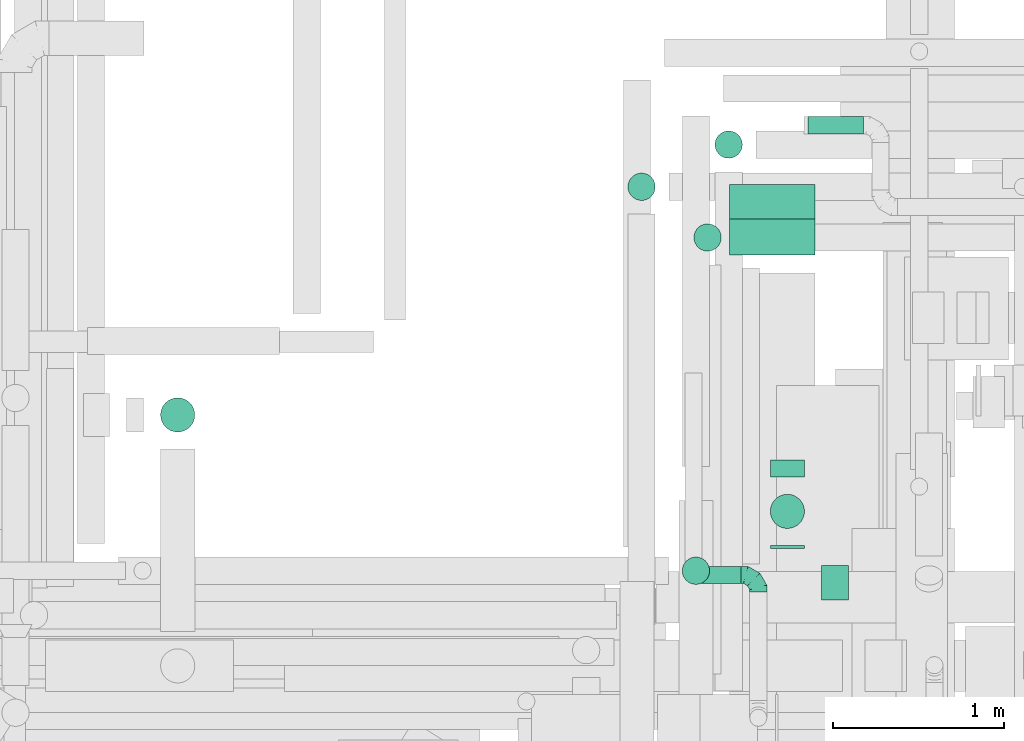
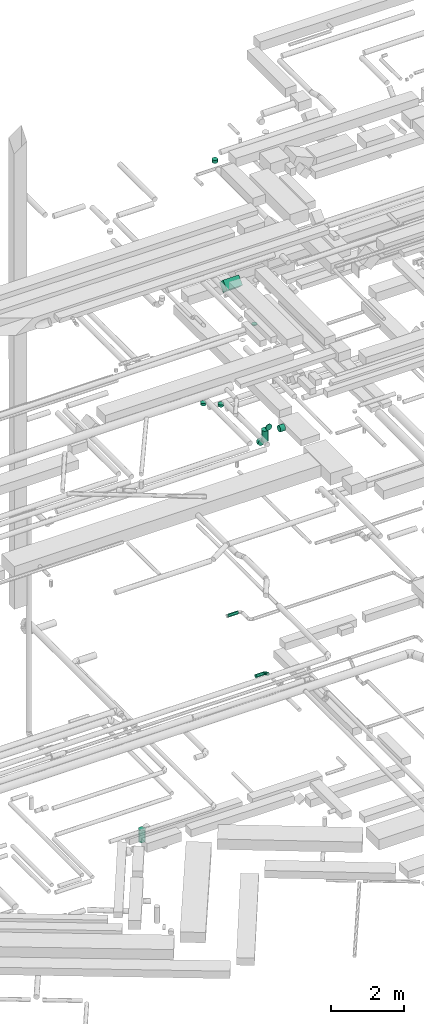
# One storey, part 108 of 337: 12 flow segments, 1 flow fitting.
"""IFC2X3 building model written with IfcOpenShell, lengths in millimetres."""

from ifc_helpers import new_model, entity, si_unit, converted_unit, derived_unit, direction, frame, frame_2d, origin, origin_2d_with_axis, place, context, subcontext, project, spatial, rectangle, circle, extrude, faceted_brep, source, transform, mapped, material, type_object, type_shapes, element, save


model = new_model("IFC2X3")

# Units and contexts
model_context = context("Model", 3, precision=0.01, world=origin(), true_north=direction((6.12303176911189e-17, 1.0)))
body_context = subcontext(model_context, "Body", "Model", "MODEL_VIEW")
ifc_project = project(units=[si_unit("LENGTHUNIT", "METRE", prefix="MILLI"), si_unit("AREAUNIT", "SQUARE_METRE"), si_unit("VOLUMEUNIT", "CUBIC_METRE"), converted_unit("PLANEANGLEUNIT", "DEGREE", entity("IfcRatioMeasure", 0.0174532925199433), si_unit("PLANEANGLEUNIT", "RADIAN"), dimensions=[0, 0, 0, 0, 0, 0, 0]), si_unit("MASSUNIT", "GRAM", prefix="KILO"), derived_unit("MASSDENSITYUNIT", [(si_unit("MASSUNIT", "GRAM", prefix="KILO"), 1), (si_unit("LENGTHUNIT", "METRE"), -3)]), derived_unit("MOMENTOFINERTIAUNIT", [(si_unit("LENGTHUNIT", "METRE"), 4)]), si_unit("TIMEUNIT", "SECOND"), si_unit("FREQUENCYUNIT", "HERTZ"), si_unit("THERMODYNAMICTEMPERATUREUNIT", "DEGREE_CELSIUS"), derived_unit("THERMALTRANSMITTANCEUNIT", [(si_unit("MASSUNIT", "GRAM", prefix="KILO"), 1), (si_unit("THERMODYNAMICTEMPERATUREUNIT", "KELVIN"), -1), (si_unit("TIMEUNIT", "SECOND"), -3)]), derived_unit("VOLUMETRICFLOWRATEUNIT", [(si_unit("LENGTHUNIT", "METRE"), 3), (si_unit("TIMEUNIT", "SECOND"), -1)]), derived_unit("MASSFLOWRATEUNIT", [(si_unit("MASSUNIT", "GRAM", prefix="KILO"), 1), (si_unit("TIMEUNIT", "SECOND"), -1)]), derived_unit("ROTATIONALFREQUENCYUNIT", [(si_unit("TIMEUNIT", "SECOND"), -1)]), si_unit("ELECTRICCURRENTUNIT", "AMPERE"), si_unit("ELECTRICVOLTAGEUNIT", "VOLT"), si_unit("POWERUNIT", "WATT"), si_unit("FORCEUNIT", "NEWTON", prefix="KILO"), si_unit("ILLUMINANCEUNIT", "LUX"), si_unit("LUMINOUSFLUXUNIT", "LUMEN"), si_unit("LUMINOUSINTENSITYUNIT", "CANDELA"), derived_unit("USERDEFINED", [(si_unit("MASSUNIT", "GRAM", prefix="KILO"), -1), (si_unit("LENGTHUNIT", "METRE"), -2), (si_unit("TIMEUNIT", "SECOND"), 3), (si_unit("LUMINOUSFLUXUNIT", "LUMEN"), 1)]), derived_unit("LINEARVELOCITYUNIT", [(si_unit("LENGTHUNIT", "METRE"), 1), (si_unit("TIMEUNIT", "SECOND"), -1)]), si_unit("PRESSUREUNIT", "PASCAL"), derived_unit("USERDEFINED", [(si_unit("LENGTHUNIT", "METRE"), -2), (si_unit("MASSUNIT", "GRAM", prefix="KILO"), 1), (si_unit("TIMEUNIT", "SECOND"), -2)]), derived_unit("LINEARFORCEUNIT", [(si_unit("MASSUNIT", "GRAM", prefix="KILO"), 1), (si_unit("LENGTHUNIT", "METRE"), 1), (si_unit("TIMEUNIT", "SECOND"), -2), (si_unit("LENGTHUNIT", "METRE"), -1)]), derived_unit("PLANARFORCEUNIT", [(si_unit("MASSUNIT", "GRAM", prefix="KILO"), 1), (si_unit("LENGTHUNIT", "METRE"), 1), (si_unit("TIMEUNIT", "SECOND"), -2), (si_unit("LENGTHUNIT", "METRE"), -2)])], contexts=[model_context])

# Site, building, storey
site_placement = place(None, origin())
site = spatial("IfcSite", under=ifc_project, at=site_placement, CompositionType="ELEMENT")
building_placement = place(site_placement, origin())
building = spatial("IfcBuilding", under=site, at=building_placement, CompositionType="ELEMENT")
storey_placement = place(building_placement, origin())
storey = spatial("IfcBuildingStorey", under=building, at=storey_placement, CompositionType="ELEMENT", Elevation=0.0)

# Flow segments
duct_segment_type_1 = type_object("IfcDuctSegmentType", PredefinedType="NOTDEFINED")
flow_segment_1_placement = place(storey_placement, frame((17425.0, 15035.4, 14906.8)))
element("IfcFlowSegment", 1, at=flow_segment_1_placement, inside=storey, type_object=duct_segment_type_1, context=body_context, shape_type="SweptSolid", body=[
    extrude(rectangle(XDim=300.0, YDim=281.801934957959, at=frame_2d((0.0, 0.0), x_axis=(0.0, 1.0))), frame((0.0, 205.7, 205.7), z_axis=(1.0, 0.0, 0.0), x_axis=(0.0, -0.707106781186551, 0.707106781186544)), (0.0, 0.0, 1.0), 499.999999999999),
])
duct_segment_type_2 = type_object("IfcDuctSegmentType", PredefinedType="NOTDEFINED")
flow_segment_2_placement = place(storey_placement, frame((14097.4, 13999.38, -1603.0)))
element("IfcFlowSegment", 2, at=flow_segment_2_placement, inside=storey, type_object=duct_segment_type_2, context=body_context, shape_type="SweptSolid", body=[
    extrude(circle(Radius=100.0, at=origin_2d_with_axis()), frame((101.6, 101.6, 0.0), z_axis=(0.0, 0.0, 1.0), x_axis=(-1.0, 0.0, 0.0)), (0.0, 0.0, 1.0), 403.000000000009),
])
flow_segment_3_placement = place(storey_placement, frame((17963.84, 13017.67, 11348.4)))
element("IfcFlowSegment", 3, at=flow_segment_3_placement, inside=storey, type_object=duct_segment_type_2, context=body_context, shape_type="SweptSolid", body=[
    extrude(circle(Radius=100.0, at=origin_2d_with_axis()), frame((0.0, 101.6, 101.6), z_axis=(1.0, 0.0, 0.0), x_axis=(0.0, 1.0, 0.0)), (0.0, 0.0, 1.0), 157.976677720794),
])
flow_segment_4_placement = place(storey_placement, frame((17248.66, 13113.76, 3348.4)))
element("IfcFlowSegment", 4, at=flow_segment_4_placement, inside=storey, type_object=duct_segment_type_2, context=body_context, shape_type="SweptSolid", body=[
    extrude(circle(Radius=50.0, at=origin_2d_with_axis()), frame((0.0, 51.6, 51.6), z_axis=(1.0, 0.0, 0.0), x_axis=(0.0, 1.0, 0.0)), (0.0, 0.0, 1.0), 245.00000000002),
])
flow_segment_5_placement = place(storey_placement, frame((17884.69, 15743.28, 3548.4)))
element("IfcFlowSegment", 5, at=flow_segment_5_placement, inside=storey, type_object=duct_segment_type_2, context=body_context, shape_type="SweptSolid", body=[
    extrude(circle(Radius=50.0, at=origin_2d_with_axis()), frame((0.0, 51.6, 51.6), z_axis=(1.0, 0.0, 0.0), x_axis=(0.0, 1.0, 0.0)), (0.0, 0.0, 1.0), 323.749999999978),
])
flow_segment_6_placement = place(storey_placement, frame((17662.24, 13319.26, 11348.4)))
element("IfcFlowSegment", 6, at=flow_segment_6_placement, inside=storey, type_object=duct_segment_type_2, context=body_context, shape_type="SweptSolid", body=[
    extrude(circle(Radius=100.0, at=origin_2d_with_axis()), frame((101.6, 0.0, 101.6), z_axis=(0.0, 1.0, 0.0), x_axis=(1.0, 0.0, 0.0)), (0.0, 0.0, 1.0), 17.8476961971333),
])
flow_segment_7_placement = place(storey_placement, frame((17662.24, 13737.11, 10578.71)))
element("IfcFlowSegment", 7, at=flow_segment_7_placement, inside=storey, type_object=duct_segment_type_2, context=body_context, shape_type="SweptSolid", body=[
    extrude(circle(Radius=100.0, at=origin_2d_with_axis()), frame((101.6, 0.0, 101.6), z_axis=(0.0, 1.0, 0.0), x_axis=(-1.0, 0.0, 0.0)), (0.0, 0.0, 1.0), 100.000000000014),
])
flow_segment_8_placement = place(storey_placement, frame((17662.24, 13435.51, 10880.3)))
element("IfcFlowSegment", 8, at=flow_segment_8_placement, inside=storey, type_object=duct_segment_type_2, context=body_context, shape_type="SweptSolid", body=[
    extrude(circle(Radius=100.0, at=origin_2d_with_axis()), frame((101.6, 101.6, 0.0), z_axis=(0.0, 0.0, 1.0), x_axis=(-1.0, 0.0, 0.0)), (0.0, 0.0, 1.0), 369.695765711637),
])
flow_segment_9_placement = place(storey_placement, frame((17215.73, 15056.69, 11230.0)))
element("IfcFlowSegment", 9, at=flow_segment_9_placement, inside=storey, type_object=duct_segment_type_2, context=body_context, shape_type="SweptSolid", body=[
    extrude(circle(Radius=80.0, at=origin_2d_with_axis()), frame((81.6, 81.6, 0.0), z_axis=(0.0, 0.0, 1.0), x_axis=(-1.0, 0.0, 0.0)), (0.0, 0.0, 1.0), 80.00000000001),
])
flow_segment_10_placement = place(storey_placement, frame((16829.74, 15353.25, 11230.0)))
element("IfcFlowSegment", 10, at=flow_segment_10_placement, inside=storey, type_object=duct_segment_type_2, context=body_context, shape_type="SweptSolid", body=[
    extrude(circle(Radius=80.0, at=origin_2d_with_axis()), frame((81.6, 81.6, 0.0), z_axis=(0.0, 0.0, 1.0), x_axis=(-1.0, 0.0, 0.0)), (0.0, 0.0, 1.0), 80.0027229055657),
])
flow_segment_11_placement = place(storey_placement, frame((17338.9, 15599.81, 19010.0)))
element("IfcFlowSegment", 11, at=flow_segment_11_placement, inside=storey, type_object=duct_segment_type_2, context=body_context, shape_type="SweptSolid", body=[
    extrude(circle(Radius=80.0, at=origin_2d_with_axis()), frame((81.6, 81.6, 0.0)), (0.0, 0.0, 1.0), 100.000000000012),
])
flow_segment_12_placement = place(storey_placement, frame((17147.62, 13108.4, 15160.0)))
element("IfcFlowSegment", 12, at=flow_segment_12_placement, inside=storey, type_object=duct_segment_type_2, context=body_context, shape_type="SweptSolid", body=[
    extrude(circle(Radius=80.0, at=origin_2d_with_axis()), frame((81.6, 81.6, 0.0), z_axis=(0.0, 0.0, 1.0), x_axis=(0.0, -1.0, 0.0)), (0.0, 0.0, 1.0), 19.9999952434063),
])

# Flow fitting
ifc_material = material()
duct_fitting_type = type_object("IfcDuctFittingType", PredefinedType="NOTDEFINED", material=ifc_material)
shared_shape = source(origin(), body_context, "Body", "Brep", [
    faceted_brep([(-100.0, 0.0, -50.0), (-100.0, -12.94, -48.3), (-100.0, -25.0, -43.3), (-100.0, -35.36, -35.36), (-100.0, -43.3, -25.0), (-100.0, -48.3, -12.94), (-100.0, -50.0, 0.0), (-100.0, -48.3, 12.94), (-100.0, -43.3, 25.0), (-100.0, -35.36, 35.36), (-100.0, -25.0, 43.3), (-100.0, -12.94, 48.3), (-100.0, 0.0, 50.0), (-100.0, 12.94, 48.3), (-100.0, 25.0, 43.3), (-100.0, 35.36, 35.36), (-100.0, 43.3, 25.0), (-100.0, 48.3, 12.94), (-100.0, 50.0, 0.0), (-100.0, 48.3, -12.94), (-100.0, 43.3, -25.0), (-100.0, 35.36, -35.36), (-100.0, 25.0, -43.3), (-100.0, 12.94, -48.3), (-76.67, 12.94, 48.3), (-79.9, 25.0, 43.3), (-73.21, 0.0, 50.0), (-82.68, 35.36, 35.36), (-86.15, 48.3, 12.94), (-86.6, 50.0, 0.0), (-84.81, 43.3, 25.0), (-84.81, 43.3, -25.0), (-82.68, 35.36, -35.36), (-86.15, 48.3, -12.94), (-76.67, 12.94, -48.3), (-73.21, 0.0, -50.0), (-79.9, 25.0, -43.3), (-69.74, -12.94, -48.3), (-66.51, -25.0, -43.3), (-63.73, -35.36, -35.36), (-61.6, -43.3, -25.0), (-60.26, -48.3, -12.94), (-59.81, -50.0, 0.0), (-60.26, -48.3, 12.94), (-61.6, -43.3, 25.0), (-63.73, -35.36, 35.36), (-66.51, -25.0, 43.3), (-69.74, -12.94, 48.3), (-36.27, 36.27, 48.3), (-45.1, 45.1, 43.3), (-26.79, 26.79, 50.0), (-52.68, 52.68, 35.36), (-58.49, 58.49, 25.0), (-62.15, 62.15, 12.94), (-63.4, 63.4, 0.0), (-62.15, 62.15, -12.94), (-58.49, 58.49, -25.0), (-52.68, 52.68, -35.36), (-36.27, 36.27, -48.3), (-26.79, 26.79, -50.0), (-45.1, 45.1, -43.3), (-17.32, 17.32, -48.3), (-8.49, 8.49, -43.3), (-0.91, 0.91, -35.36), (4.9, -4.9, -25.0), (8.56, -8.56, -12.94), (9.81, -9.81, 0.0), (8.56, -8.56, 12.94), (4.9, -4.9, 25.0), (-0.91, 0.91, 35.36), (-8.49, 8.49, 43.3), (-17.32, 17.32, 48.3), (-12.94, 76.67, 48.3), (-25.0, 79.9, 43.3), (0.0, 73.21, 50.0), (-35.36, 82.68, 35.36), (-43.3, 84.81, 25.0), (-48.3, 86.15, 12.94), (-50.0, 86.6, 0.0), (-48.3, 86.15, -12.94), (-43.3, 84.81, -25.0), (-35.36, 82.68, -35.36), (-12.94, 76.67, -48.3), (0.0, 73.21, -50.0), (-25.0, 79.9, -43.3), (12.94, 69.74, -48.3), (25.0, 66.51, -43.3), (35.36, 63.73, -35.36), (43.3, 61.6, -25.0), (48.3, 60.26, -12.94), (50.0, 59.81, 0.0), (48.3, 60.26, 12.94), (43.3, 61.6, 25.0), (35.36, 63.73, 35.36), (25.0, 66.51, 43.3), (12.94, 69.74, 48.3), (-12.94, 100.0, -48.3), (-25.0, 100.0, -43.3), (-35.36, 100.0, -35.36), (-43.3, 100.0, -25.0), (-48.3, 100.0, -12.94), (-50.0, 100.0, 0.0), (-48.3, 100.0, 12.94), (-43.3, 100.0, 25.0), (-35.36, 100.0, 35.36), (-25.0, 100.0, 43.3), (-12.94, 100.0, 48.3), (0.0, 100.0, 50.0), (12.94, 100.0, 48.3), (25.0, 100.0, 43.3), (35.36, 100.0, 35.36), (43.3, 100.0, 25.0), (48.3, 100.0, 12.94), (50.0, 100.0, 0.0), (48.3, 100.0, -12.94), (43.3, 100.0, -25.0), (35.36, 100.0, -35.36), (25.0, 100.0, -43.3), (12.94, 100.0, -48.3), (0.0, 100.0, -50.0)], [[[0, 1, 2, 3, 4, 5, 6, 7, 8, 9, 10, 11, 12, 13, 14, 15, 16, 17, 18, 19, 20, 21, 22, 23]], [[24, 25, 14, 13]], [[26, 24, 13, 12]], [[14, 25, 27, 15]], [[28, 29, 18, 17]], [[30, 28, 17, 16]], [[15, 27, 30, 16]], [[20, 31, 32, 21]], [[33, 31, 20, 19]], [[18, 29, 33, 19]], [[34, 35, 0, 23]], [[36, 34, 23, 22]], [[32, 36, 22, 21]], [[2, 1, 37, 38]], [[3, 2, 38, 39]], [[0, 35, 37, 1]], [[5, 4, 40, 41]], [[6, 5, 41, 42]], [[3, 39, 40, 4]], [[6, 42, 43, 7]], [[7, 43, 44, 8]], [[8, 44, 45, 9]], [[10, 46, 47, 11]], [[11, 47, 26, 12]], [[10, 9, 45, 46]], [[48, 49, 25, 24]], [[50, 48, 24, 26]], [[27, 25, 49, 51]], [[52, 53, 28, 30]], [[51, 52, 30, 27]], [[29, 28, 53, 54]], [[55, 56, 31, 33]], [[54, 55, 33, 29]], [[57, 32, 31, 56]], [[58, 59, 35, 34]], [[60, 58, 34, 36]], [[57, 60, 36, 32]], [[37, 35, 59, 61]], [[38, 37, 61, 62]], [[39, 38, 62, 63]], [[41, 40, 64, 65]], [[42, 41, 65, 66]], [[63, 64, 40, 39]], [[43, 42, 66, 67]], [[44, 43, 67, 68]], [[68, 69, 45, 44]], [[46, 45, 69, 70]], [[47, 46, 70, 71]], [[26, 47, 71, 50]], [[72, 73, 49, 48]], [[74, 72, 48, 50]], [[51, 49, 73, 75]], [[76, 77, 53, 52]], [[75, 76, 52, 51]], [[54, 53, 77, 78]], [[79, 80, 56, 55]], [[78, 79, 55, 54]], [[81, 57, 56, 80]], [[82, 83, 59, 58]], [[84, 82, 58, 60]], [[81, 84, 60, 57]], [[61, 59, 83, 85]], [[62, 61, 85, 86]], [[63, 62, 86, 87]], [[65, 64, 88, 89]], [[66, 65, 89, 90]], [[87, 88, 64, 63]], [[67, 66, 90, 91]], [[68, 67, 91, 92]], [[92, 93, 69, 68]], [[70, 69, 93, 94]], [[71, 70, 94, 95]], [[50, 71, 95, 74]], [[96, 97, 98, 99, 100, 101, 102, 103, 104, 105, 106, 107, 108, 109, 110, 111, 112, 113, 114, 115, 116, 117, 118, 119]], [[72, 74, 107, 106]], [[73, 72, 106, 105]], [[75, 73, 105, 104]], [[77, 76, 103, 102]], [[78, 77, 102, 101]], [[75, 104, 103, 76]], [[78, 101, 100, 79]], [[79, 100, 99, 80]], [[80, 99, 98, 81]], [[96, 119, 83, 82]], [[97, 96, 82, 84]], [[84, 81, 98, 97]], [[83, 119, 118, 85]], [[85, 118, 117, 86]], [[86, 117, 116, 87]], [[88, 115, 114, 89]], [[89, 114, 113, 90]], [[87, 116, 115, 88]], [[91, 90, 113, 112]], [[92, 91, 112, 111]], [[93, 92, 111, 110]], [[95, 94, 109, 108]], [[74, 95, 108, 107]], [[110, 109, 94, 93]]]),
])
type_shapes(duct_fitting_type, [shared_shape])
flow_fitting_placement = place(storey_placement, frame((17593.66, 13165.36, 3400.0), z_axis=(0.0, 0.0, 1.0), x_axis=(0.0, 1.0, 0.0)))
element("IfcFlowFitting", 13, at=flow_fitting_placement, inside=storey, type_object=duct_fitting_type, material=ifc_material, context=body_context, shape_type="MappedRepresentation", body=[
    mapped(shared_shape, transform((0.0, 0.0, 0.0), scale=1.0)),
])

save(model, "model.ifc")
